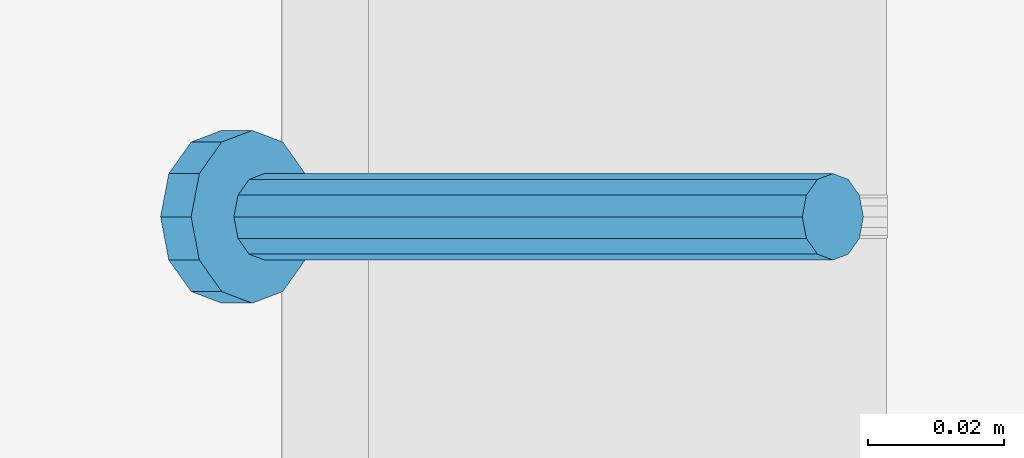
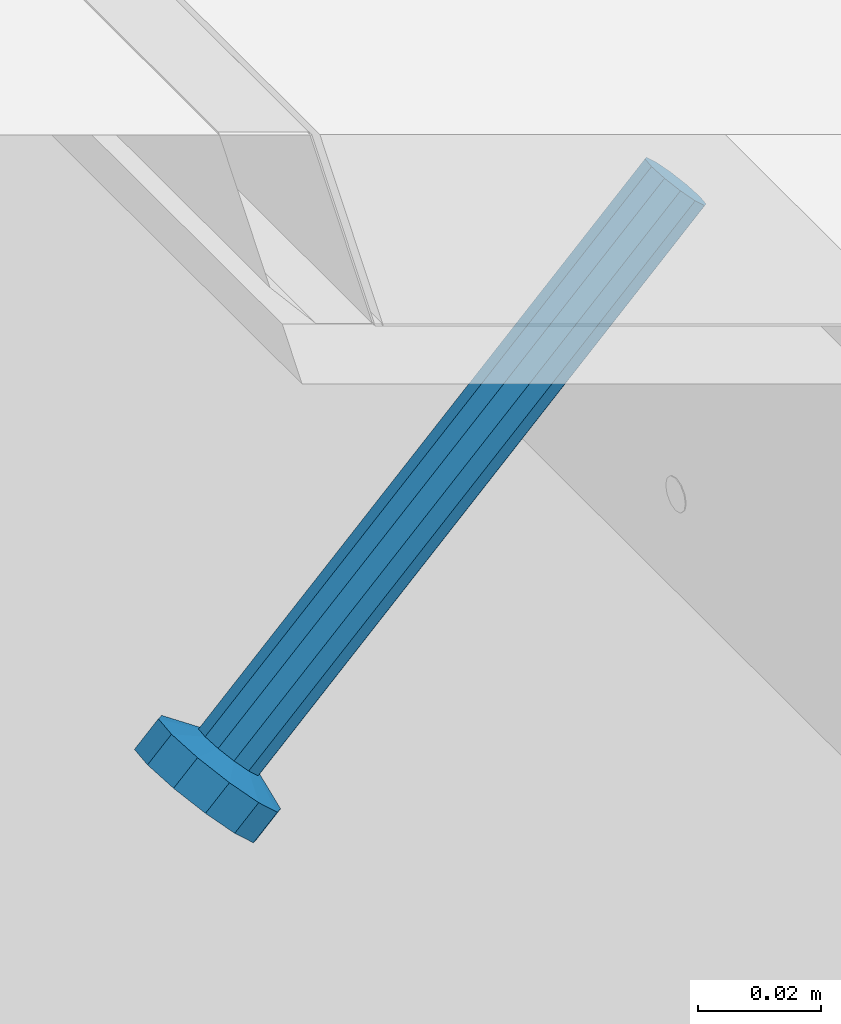
# One storey, part 2525 of 3843: 1 member, 1 element without a shape of its own.
"""IFC2X3 building model written with IfcOpenShell, lengths in millimetres."""

from ifc_helpers import new_model, si_unit, frame, origin_with_axes, place, context, subcontext, project, spatial, faceted_brep, material, type_object, element, aggregate, save


model = new_model("IFC2X3")

# Units and contexts
model_context = context("Model", 3, precision=1e-05, world=origin_with_axes())
body_context = subcontext(model_context, "Body", "Model", "MODEL_VIEW")
ifc_project = project(units=[si_unit("LENGTHUNIT", "METRE", prefix="MILLI"), si_unit("AREAUNIT", "SQUARE_METRE"), si_unit("VOLUMEUNIT", "CUBIC_METRE"), si_unit("MASSUNIT", "GRAM", prefix="KILO"), si_unit("TIMEUNIT", "SECOND"), si_unit("PLANEANGLEUNIT", "RADIAN"), si_unit("SOLIDANGLEUNIT", "STERADIAN"), si_unit("THERMODYNAMICTEMPERATUREUNIT", "DEGREE_CELSIUS"), si_unit("LUMINOUSINTENSITYUNIT", "LUMEN")], contexts=[model_context])

# Site, building, storey
site_placement = place(None, origin_with_axes())
site = spatial("IfcSite", under=ifc_project, at=site_placement, CompositionType="ELEMENT")
building_placement = place(site_placement, origin_with_axes())
building = spatial("IfcBuilding", under=site, at=building_placement, Name="Undefined", CompositionType="ELEMENT")
storey_placement = place(building_placement, origin_with_axes())
storey = spatial("IfcBuildingStorey", under=building, at=storey_placement, Name="Undefined", CompositionType="ELEMENT", Elevation=0.0)

# Assembly, member
assembly_placement = place(storey_placement, origin_with_axes())
assembly = element("IfcElementAssembly", 1, at=assembly_placement, inside=storey, Name="EMBED_ANGLE", AssemblyPlace="NOTDEFINED", PredefinedType="RIGID_FRAME")
ifc_material = material(Name="STEEL/A108")
member_type = type_object("IfcMemberType", PredefinedType="NOTDEFINED")
member_placement = place(assembly_placement, frame((65137.5380556641, 87737.8227092285, 30446.6625), z_axis=(0.0, 1.0, 0.0), x_axis=(-0.707106781186548, 0.0, -0.707106781186548)))
member = element("IfcMember", 2, at=member_placement, type_object=member_type, material=ifc_material, Name="HEADED STUD ANCHOR", context=body_context, shape_type="Brep", body=[
    faceted_brep([(7.27595761418343e-12, -3.18000006675175, 5.5), (0.0, -5.49999999998363, 3.1800000667572), (118.110000000976, -5.49999999999091, 3.1800000667572), (118.110000000983, -3.18000006675175, 5.5), (0.0, -6.3499999046162, 0.0), (118.110000000968, -6.34999990461256, 0.0), (0.0, -5.49999999998363, -3.1800000667572), (118.110000000976, -5.49999999999091, -3.1800000667572), (7.27595761418343e-12, -3.18000006675175, -5.5), (118.110000000983, -3.18000006675175, -5.5), (7.27595761418343e-12, -1.81898940354586e-12, -6.34999990463257), (118.110000000968, -1.81898940354586e-12, -6.34999990463257), (0.0, 3.18000006675175, -5.5), (118.110000000968, 3.18000006674811, -5.5), (7.27595761418343e-12, 5.49999999998363, -3.1800000667572), (118.110000000983, 5.49999999998363, -3.1800000667572), (7.27595761418343e-12, 6.3499999046162, 0.0), (118.110000000976, 6.34999990461256, 0.0), (7.27595761418343e-12, 5.49999999998363, 3.1800000667572), (118.110000000983, 5.49999999998363, 3.1800000667572), (0.0, 3.18000006675175, 5.5), (118.110000000968, 3.18000006674811, 5.5), (7.27595761418343e-12, -1.81898940354586e-12, 6.34999990463257), (118.110000000968, -1.81898940354586e-12, 6.34999990463257), (120.650000000991, -10.9899997710909, 6.34999990463257), (120.650000000998, -6.34000015257152, 10.9899997711182), (120.650000000991, -12.6999998092379, 0.0), (120.650000000991, -10.9899997710909, -6.34999990463257), (120.650000000998, -6.34000015257152, -10.9899997711182), (120.650000000991, -1.81898940354586e-12, -12.6899995803833), (120.650000000991, 6.34000015257152, -10.9899997711182), (120.650000000998, 10.9899997710909, -6.34999990463257), (120.650000000991, 12.6999998092342, 0.0), (120.650000000998, 10.9899997710909, 6.34999990463257), (120.650000000991, 6.34000015257152, 10.9899997711182), (120.650000000991, -1.81898940354586e-12, 12.6899995803833), (127.000000001048, -10.9899997710945, 6.34999990463257), (127.000000001048, -6.34000015257152, 10.9899997711182), (127.000000001048, -12.6999998092342, 0.0), (127.000000001048, -10.9899997710945, -6.34999990463257), (127.000000001048, -6.34000015257152, -10.9899997711182), (127.000000001048, 1.81898940354586e-12, -12.6899995803833), (127.000000001048, 6.34000015256788, -10.9899997711182), (127.000000001048, 10.9899997710909, -6.34999990463257), (127.000000001048, 12.6999998092379, 0.0), (127.000000001048, 10.9899997710909, 6.34999990463257), (127.000000001048, 6.34000015256788, 10.9899997711182), (127.000000001048, 1.81898940354586e-12, 12.6899995803833)], [[[0, 1, 2, 3]], [[1, 4, 5, 2]], [[4, 6, 7, 5]], [[6, 8, 9, 7]], [[8, 10, 11, 9]], [[10, 12, 13, 11]], [[12, 14, 15, 13]], [[14, 16, 17, 15]], [[16, 18, 19, 17]], [[18, 20, 21, 19]], [[20, 22, 23, 21]], [[22, 0, 3, 23]], [[22, 20, 18, 16, 14, 12, 10, 8, 6, 4, 1, 0]], [[3, 2, 24, 25]], [[2, 5, 26, 24]], [[5, 7, 27, 26]], [[7, 9, 28, 27]], [[9, 11, 29, 28]], [[11, 13, 30, 29]], [[13, 15, 31, 30]], [[15, 17, 32, 31]], [[17, 19, 33, 32]], [[19, 21, 34, 33]], [[21, 23, 35, 34]], [[23, 3, 25, 35]], [[25, 24, 36, 37]], [[24, 26, 38, 36]], [[26, 27, 39, 38]], [[27, 28, 40, 39]], [[28, 29, 41, 40]], [[29, 30, 42, 41]], [[30, 31, 43, 42]], [[31, 32, 44, 43]], [[32, 33, 45, 44]], [[33, 34, 46, 45]], [[34, 35, 47, 46]], [[35, 25, 37, 47]], [[38, 39, 40, 41, 42, 43, 44, 45, 46, 47, 37, 36]]]),
])
aggregate(assembly, [member])

save(model, "model.ifc")
